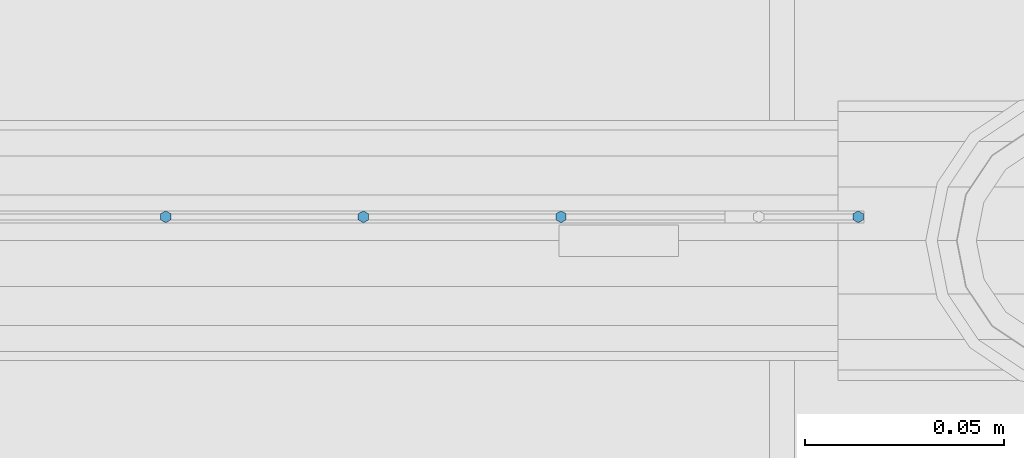
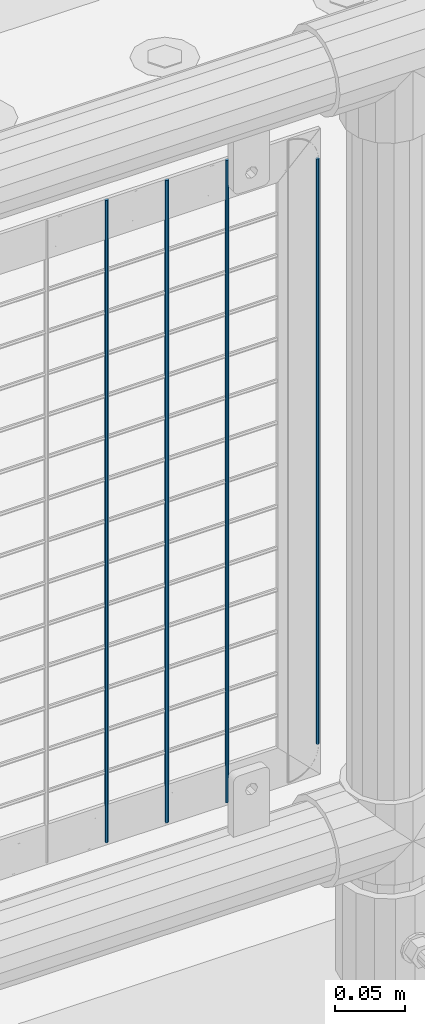
# One storey, part 76 of 208: 4 columns.
"""IFC2X3 building model written with IfcOpenShell, lengths in millimetres."""

from ifc_helpers import new_model, si_unit, frame, origin_with_axes, place, context, subcontext, project, spatial, faceted_brep, material, type_object, element, save


model = new_model("IFC2X3")

# Units and contexts
model_context = context("Model", 3, precision=1e-05, world=origin_with_axes())
body_context = subcontext(model_context, "Body", "Model", "MODEL_VIEW")
ifc_project = project(units=[si_unit("LENGTHUNIT", "METRE", prefix="MILLI"), si_unit("AREAUNIT", "SQUARE_METRE"), si_unit("VOLUMEUNIT", "CUBIC_METRE"), si_unit("MASSUNIT", "GRAM", prefix="KILO"), si_unit("TIMEUNIT", "SECOND"), si_unit("PLANEANGLEUNIT", "RADIAN"), si_unit("SOLIDANGLEUNIT", "STERADIAN"), si_unit("THERMODYNAMICTEMPERATUREUNIT", "DEGREE_CELSIUS"), si_unit("LUMINOUSINTENSITYUNIT", "LUMEN")], contexts=[model_context])

# Site, building, storey
site_placement = place(None, origin_with_axes())
site = spatial("IfcSite", under=ifc_project, at=site_placement, CompositionType="ELEMENT")
building_placement = place(site_placement, origin_with_axes())
building = spatial("IfcBuilding", under=site, at=building_placement, Name="Standard", CompositionType="ELEMENT")
storey_placement = place(building_placement, origin_with_axes())
storey = spatial("IfcBuildingStorey", under=building, at=storey_placement, Name="Undefined", CompositionType="ELEMENT", Elevation=0.0)

# Columns
ifc_material = material(Name="Misc_Undefined")
column_type = type_object("IfcColumnType", Name="D3", PredefinedType="NOTDEFINED")
for number, where, z_axis, x_axis in (
    (1, (-32358.66, 4670.50000000001, 353.020000000003), (-1.0, 0.0, 0.0), (0.0, 0.0, 1.0)),
    (2, (-32408.315, 4670.50000000001, 353.020000000003), (-1.0, 0.0, 0.0), (0.0, 0.0, 1.0)),
    (3, (-32457.97, 4670.50000000001, 353.020000000003), (-1.0, 0.0, 0.0), (0.0, 0.0, 1.0)),
):
    element("IfcColumn", number, at=place(storey_placement, frame(where, z_axis=z_axis, x_axis=x_axis)), inside=storey, type_object=column_type, material=ifc_material, ObjectType="D3", context=body_context, shape_type="Brep", body=[
        faceted_brep([(0.0, -1.49999999999909, 3.63797880709171e-12), (-7.27595761418343e-12, -0.749999999999091, -1.29903810567669), (560.0, -0.75, -1.29903810567703), (560.0, -1.5, 0.0), (-3.63797880709171e-12, 0.750000000000909, -1.29903810567669), (560.0, 0.75, -1.29903810567703), (0.0, 1.50000000000182, 3.63797880709171e-12), (560.0, 1.5, 0.0), (-3.63797880709171e-12, 0.750000000000909, 1.29903810567669), (560.0, 0.75, 1.29903810567703), (-7.27595761418343e-12, -0.749999999999091, 1.29903810567669), (560.0, -0.75, 1.29903810567703)], [[[0, 1, 2, 3]], [[1, 4, 5, 2]], [[4, 6, 7, 5]], [[6, 8, 9, 7]], [[8, 10, 11, 9]], [[10, 0, 3, 11]], [[5, 7, 9, 11, 3, 2]], [[10, 8, 6, 4, 1, 0]]]),
    ])
column_placement = place(storey_placement, frame((-32284.0, 4670.5, 378.020000000003), z_axis=(-1.0, 0.0, 0.0), x_axis=(0.0, 0.0, 1.0)))
element("IfcColumn", 4, at=column_placement, inside=storey, type_object=column_type, material=ifc_material, ObjectType="D3", context=body_context, shape_type="Brep", body=[
    faceted_brep([(0.0, -1.49999999999909, 3.63797880709171e-12), (-7.27595761418343e-12, -0.749999999999091, -1.29903810567669), (510.0, -0.75, -1.29903810567703), (510.0, -1.5, 0.0), (-3.63797880709171e-12, 0.750000000000909, -1.29903810567669), (510.0, 0.75, -1.29903810567703), (0.0, 1.50000000000182, 3.63797880709171e-12), (510.0, 1.5, 0.0), (-3.63797880709171e-12, 0.750000000000909, 1.29903810567669), (510.0, 0.75, 1.29903810567703), (-7.27595761418343e-12, -0.749999999999091, 1.29903810567669), (510.0, -0.75, 1.29903810567703)], [[[0, 1, 2, 3]], [[1, 4, 5, 2]], [[4, 6, 7, 5]], [[6, 8, 9, 7]], [[8, 10, 11, 9]], [[10, 0, 3, 11]], [[5, 7, 9, 11, 3, 2]], [[10, 8, 6, 4, 1, 0]]]),
])

save(model, "model.ifc")
